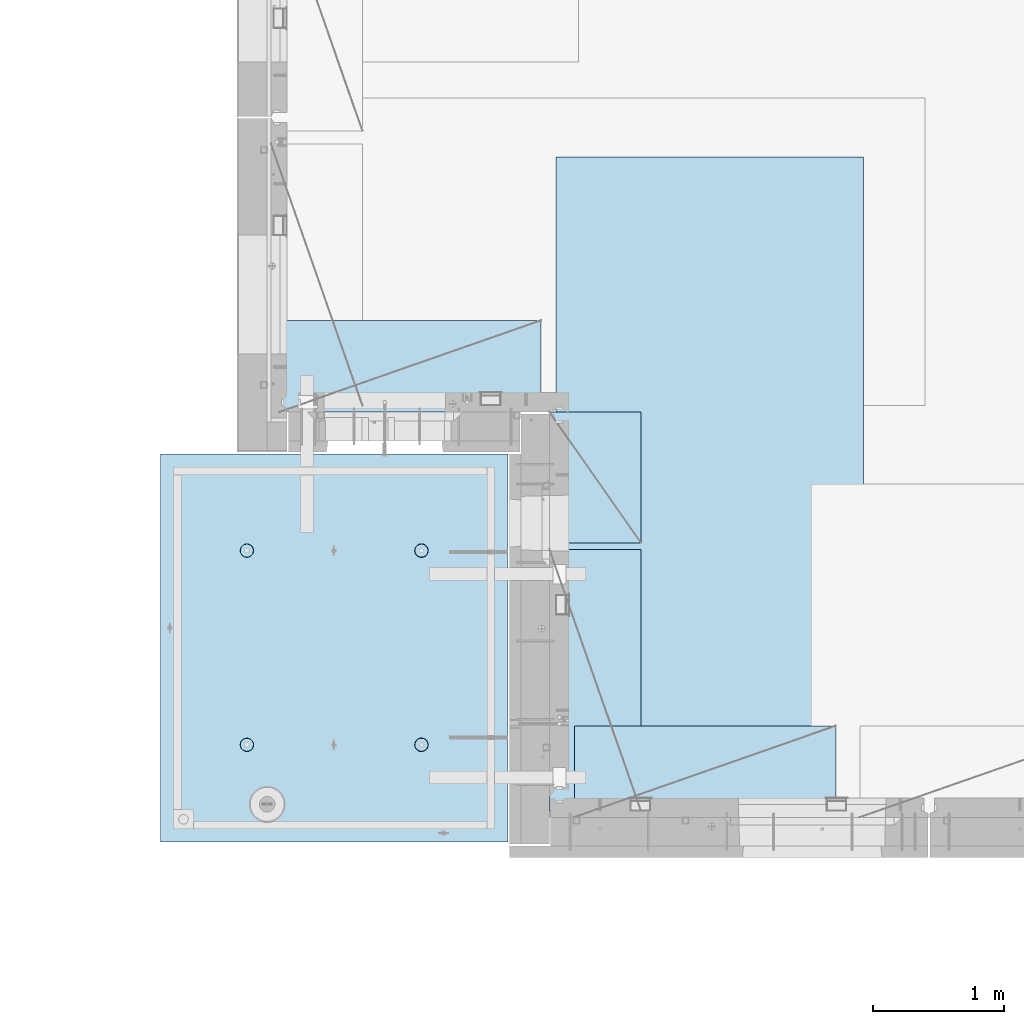
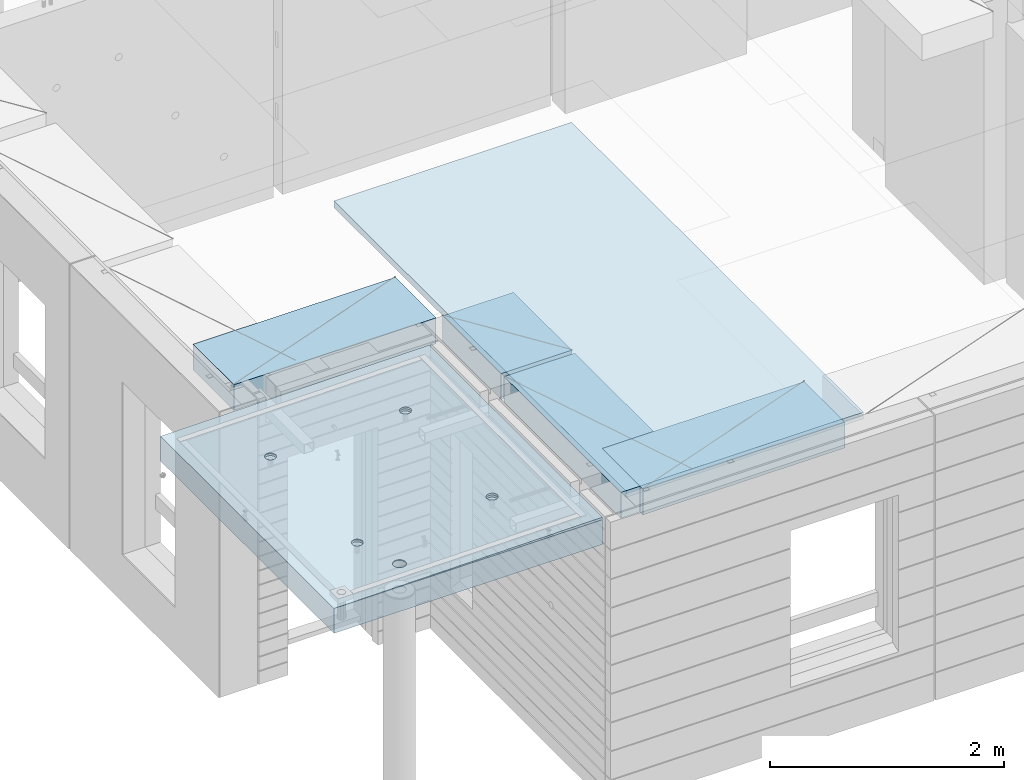
# One storey, part 192 of 334: 5 plates, 2 slabs, 6 elements without a shape of their own.
"""IFC2X3 building model written with IfcOpenShell, lengths in millimetres."""

from ifc_helpers import new_model, si_unit, frame, origin_with_axes, place, context, subcontext, project, spatial, faceted_brep, material, type_object, element, aggregate, save


model = new_model("IFC2X3")

# Units and contexts
model_context = context("Model", 3, precision=1e-05, world=origin_with_axes())
body_context = subcontext(model_context, "Body", "Model", "MODEL_VIEW")
ifc_project = project(units=[si_unit("LENGTHUNIT", "METRE", prefix="MILLI"), si_unit("AREAUNIT", "SQUARE_METRE"), si_unit("VOLUMEUNIT", "CUBIC_METRE"), si_unit("MASSUNIT", "GRAM", prefix="KILO"), si_unit("TIMEUNIT", "SECOND"), si_unit("PLANEANGLEUNIT", "RADIAN"), si_unit("SOLIDANGLEUNIT", "STERADIAN"), si_unit("THERMODYNAMICTEMPERATUREUNIT", "DEGREE_CELSIUS"), si_unit("LUMINOUSINTENSITYUNIT", "LUMEN")], contexts=[model_context])

# Site, building, storey
site_placement = place(None, origin_with_axes())
site = spatial("IfcSite", under=ifc_project, at=site_placement, CompositionType="ELEMENT")
building_placement = place(site_placement, origin_with_axes())
building = spatial("IfcBuilding", under=site, at=building_placement, CompositionType="ELEMENT")
storey_placement = place(building_placement, origin_with_axes())
storey = spatial("IfcBuildingStorey", under=building, at=storey_placement, Name="3", CompositionType="ELEMENT", Elevation=0.0)

# Assembly, slabs
assembly_1_placement = place(storey_placement, origin_with_axes())
assembly_1 = element("IfcElementAssembly", 1, at=assembly_1_placement, inside=storey, AssemblyPlace="NOTDEFINED", PredefinedType="REINFORCEMENT_UNIT")
ifc_material_1 = material(Name="CONCRETE/C35/45")
slab_type_1 = type_object("IfcSlabType", PredefinedType="NOTDEFINED")
slab_1_placement = place(assembly_1_placement, frame((9690.00344264774, 7659.99985681325, 90717.5), z_axis=(-1.0, 3.00000001838171e-08, 0.0), x_axis=(0.0, 1.0, 0.0)))
slab_1 = element("IfcSlab", 2, at=slab_1_placement, type_object=slab_type_1, material=ifc_material_1, PredefinedType="FLOOR", context=body_context, shape_type="Brep", body=[
    faceted_brep([(2970.0, 12.5, 2076.56396484375), (2970.0, 12.5, 2655.10375976563), (2970.0, 7.05330645262438, 2076.56396484375), (2970.0, 12.5, 0.0), (2969.99999999997, -12.5000027287315, -0.000215120240682154), (7.41420080885291e-08, 12.4999999999927, 0.0), (-7.41420080885291e-08, -12.5, -3.63797880709171e-12), (0.0, 12.5, 2655.00366210938), (2246.17288192116, -6.7539579669974, 610.235903379627), (2245.81872714612, 12.5, 611.325879700402), (2230.00000005311, 12.5, 608.820439463128), (2230.00000005311, -6.77809034052189, 607.672934085716), (2260.76019932669, -6.68392947182292, 617.673133503364), (2260.0890070157, 12.5, 618.596950465364), (2272.332530811, -6.57487936261168, 629.254531739907), (2271.41396524135, 12.5, 629.921908691014), (2279.75709784774, -6.43750647555862, 643.843854552742), (2278.68503600632, 12.5, 644.192188560603), (2282.30864751904, -6.2852774275234, 660.010915653605), (2281.19047624359, 12.5, 660.010915653605), (2279.73986529519, -6.13310092446045, 676.172377558725), (2278.68503600632, 12.5, 675.829642746608), (2272.30464795307, -5.995865551522, 690.747041485218), (2271.41396524135, 12.5, 690.099922616197), (2260.73231646608, -5.88698525390646, 702.310320338618), (2260.0890070157, 12.5, 701.424880841847), (2246.15564936427, -5.81709377811057, 709.732891570933), (2245.81872714612, 12.5, 708.695951606809), (2230.00000005311, -5.7930130083696, 712.290261666009), (2230.00000005311, 12.5, 711.201391844083), (2213.8443507625, -5.8170926610037, 709.732891507694), (2214.18127296011, 12.5, 708.695951606811), (2199.2676837145, -5.88698312871566, 702.310320236276), (2199.91099309052, 12.5, 701.424880841847), (2187.69535229405, -5.99586262571393, 690.747041382852), (2188.58603486487, 12.5, 690.099922616197), (2180.26013500581, -6.13309748387837, 676.172377495441), (2181.31496409991, 12.5, 675.829642746608), (2177.6913528026, -6.28527380865125, 660.010915653605), (2178.80952386264, 12.5, 660.010915653605), (2180.24290245339, -6.43750303260458, 643.843854616072), (2181.31496409991, 12.5, 644.192188560603), (2187.66746943631, -6.57487643294735, 629.254531842409), (2188.58603486487, 12.5, 629.921908691014), (2199.23980085403, -6.68392734277586, 617.673133605889), (2199.91099309052, 12.5, 618.596950465364), (2213.82711820565, -6.75395684751857, 610.235903443003), (2214.18127296011, 12.5, 611.325879700402), (761.172882674973, -6.75400078258826, 610.225900828256), (760.818727112381, 12.5, 611.315879572843), (745.000000019378, 12.5, 608.81043933557), (745.000000019378, -6.77813315729145, 607.662931409541), (775.760200790834, -6.68397228400863, 617.663131314152), (775.089006981969, 12.5, 618.586950337805), (787.33253283866, -6.57492216948594, 629.244530114656), (786.413965207619, 12.5, 629.911908563456), (794.757100236948, -6.437549275739, 643.833853637923), (793.685035972581, 12.5, 644.182188433044), (797.308650032492, -6.28532022031141, 660.000915526047), (796.190476209855, 12.5, 660.000915526047), (794.739867683551, -6.13314370981243, 676.162378218156), (793.685035972581, 12.5, 675.81964261905), (787.304649979378, -5.9959083302092, 690.737042854367), (786.413965207619, 12.5, 690.089922488638), (775.732317928869, -5.88702802728221, 702.300322270843), (775.089006981969, 12.5, 701.414880714288), (761.155650117242, -5.81713654809573, 709.722893864604), (760.818727112381, 12.5, 708.68595147925), (745.000000019378, -5.79305577717605, 712.280264084213), (745.000000019378, 12.5, 711.191391716524), (728.844349942063, -5.8171354309743, 709.722893801363), (729.181272926375, 12.5, 708.68595147925), (714.267682184241, -5.88702590207686, 702.300322168503), (714.910993056787, 12.5, 701.414880714288), (702.695350200273, -5.99590540440113, 690.737042752), (703.586034831136, 12.5, 690.089922488638), (695.260132549976, -6.1331402692449, 676.16237815487), (696.314964066174, 12.5, 675.81964261905), (692.691350221674, -6.28531660142471, 660.000915526047), (693.809523828902, 12.5, 660.000915526047), (695.242899996714, -6.43754583279951, 643.833853701251), (696.314964066174, 12.5, 644.182188433044), (702.667467341174, -6.57491923982161, 629.244530217156), (703.586034831136, 12.5, 629.911908563456), (714.239799322411, -6.68397015496157, 617.663131416677), (714.910993056787, 12.5, 618.586950337805), (728.827117384375, -6.75399966310943, 610.225900891632), (729.181272926375, 12.5, 611.315879572843), (760.941541335169, 5.82308796475991, 1945.93972725137), (760.818727091786, 12.5, 1946.31771062636), (744.999999998783, 12.5, 1943.81227038909), (744.999999998783, 5.79930078610778, 1943.4134192454), (775.320198478928, 5.89211475661432, 1953.2705735664), (775.089006961374, 12.5, 1953.58878139132), (786.72699673669, 5.99960498859582, 1964.68630888353), (786.413965187025, 12.5, 1964.91373961697), (794.045361100365, 6.13501286304381, 1979.06694274881), (793.685035951987, 12.5, 1979.18401948656), (796.560412832556, 6.28506439260673, 1995.00274657956), (796.190476189258, 12.5, 1995.00274657956), (794.028375046106, 6.43506412883289, 2010.93303130673), (793.685035951987, 12.5, 2010.82147367257), (786.699512721421, 6.57033645619231, 2025.29921596966), (786.413965187025, 12.5, 2025.09175354215), (775.292714461017, 6.67765930559835, 2036.69709108738), (775.089006961374, 12.5, 2036.41671176781), (760.924555276639, 6.74655103802797, 2044.01348819506), (760.818727091786, 12.5, 2043.68778253277), (744.999999998783, 6.7702873510425, 2046.53427709438), (744.999999998783, 12.5, 2046.19322277004), (729.075444741182, 6.7465521391714, 2044.01348813272), (729.18127290578, 12.5, 2043.68778253277), (714.70728560984, 6.67766140039021, 2036.6970909865), (714.910993036192, 12.5, 2036.41671176781), (703.300487415023, 6.57033934014908, 2025.29921586876), (703.586034810542, 12.5, 2025.09175354216), (695.971625143447, 6.43506752018584, 2010.93303124435), (696.314964045579, 12.5, 2010.82147367257), (693.439587377337, 6.28506795971771, 1995.00274657956), (693.809523808306, 12.5, 1995.00274657956), (695.954639089321, 6.13501625673962, 1979.06694281123), (696.314964045579, 12.5, 1979.18401948656), (703.273003399938, 5.99960787635064, 1964.68630898457), (703.586034810542, 12.5, 1964.91373961697), (714.679801592063, 5.89211685521877, 1953.27057366746), (714.910993036192, 12.5, 1953.58878139132), (729.058458682694, 5.82308906823164, 1945.93972731384), (729.18127290578, 12.5, 1946.31771062636), (2178.80952377932, 12.5, 1995.00274667064), (2178.43958429075, 6.28501659208268, 1995.00274667064), (2180.95463615188, 6.13496488021337, 1979.06694195729), (2181.31496401659, 12.5, 1979.18401957764), (2181.31496401659, 12.5, 2010.82147376364), (2180.97162220701, 6.43501616145659, 2010.93303228012), (2188.58603478155, 12.5, 2025.09175363323), (2188.3004849132, 6.57028798943793, 2025.29921775646), (2199.9109930072, 12.5, 2036.41671185888), (2199.70728378446, 6.6776100560528, 2036.6970935501), (2214.18127287679, 12.5, 2043.68778262385), (2214.07544376785, 6.74650079890853, 2044.0134911302), (2229.9999999698, 12.5, 2046.19322286112), (2229.9999999698, 6.77023601217661, 2046.53428024135), (2245.8187270628, 12.5, 2043.68778262385), (2245.924556192, 6.7464996977651, 2044.01349119253), (2260.08900693239, 12.5, 2036.41671185888), (2260.29271622843, 6.67760796126095, 2036.69709365098), (2271.41396515804, 12.5, 2025.09175363323), (2271.69951516527, 6.57028510548116, 2025.29921785736), (2278.685035923, 12.5, 2010.82147376364), (2279.02837792456, 6.43501277010364, 2010.9330323425), (2281.19047616027, 12.5, 1995.00274667064), (2281.56041586117, 6.2850130249717, 1995.00274667064), (2278.685035923, 12.5, 1979.18401957764), (2279.04536397983, 6.13496148651757, 1979.06694189487), (2271.41396515804, 12.5, 1964.91373970805), (2271.72699918216, 5.99955360403692, 1964.68630717681), (2260.08900693239, 12.5, 1953.5887814824), (2260.32020024797, 5.89206336568168, 1953.2705711827), (2245.8187270628, 12.5, 1946.31771071744), (2245.94154225154, 5.82303656973818, 1945.93972443295), (254.731823253564, 4.36849820162752, 1791.45731182264), (241.457918728614, 4.49348581883532, 1804.73121634759), (232.935547413403, 4.65097912067722, 1821.45731182264), (229.998938391112, 4.82556156541978, 1839.99833148514), (232.935547413403, 5.00014380698849, 1858.53935114764), (241.457918728614, 5.15763651921588, 1875.26544662269), (254.731823253564, 5.28262321809598, 1888.53935114764), (271.457918728614, 5.36286933471274, 1897.06172246285), (289.998938391112, 5.3905198200664, 1899.99833148514), (308.539958053609, 5.36286805199052, 1897.06172246285), (325.26605352866, 5.28262077822001, 1888.53935114764), (338.539958053609, 5.15763316099765, 1875.26544662269), (347.06232936882, 5.0001398591703, 1858.53935114764), (349.998938391112, 4.82555741442775, 1839.99833148514), (347.06232936882, 4.65097517284448, 1821.45731182264), (338.539958053609, 4.49348246061709, 1804.73121634759), (325.26605352866, 4.36849576173699, 1791.45731182264), (308.539958053609, 4.28824964510568, 1782.93494050743), (289.998938391112, 4.26059915976657, 1779.99833148514), (271.457918728614, 4.28825092784246, 1782.93494050743), (2199.67979976505, 5.89206546428613, 1953.27057128376), (2188.27300089649, 5.99955649179174, 1964.68630727784), (2229.9999999698, 5.79924938967451, 1943.41341627717), (2214.05845770835, 5.82303767320991, 1945.93972449542), (2188.58603478155, 12.5, 1964.91373970805), (2199.9109930072, 12.5, 1953.5887814824), (2214.18127287679, 12.5, 1946.31771071744), (2229.9999999698, 12.5, 1943.81227048017), (325.26605352866, 12.5, 1791.45731182264), (338.539958053609, 12.5, 1804.73121634759), (347.06232936882, 12.5, 1821.45731182264), (349.998938391112, 12.5, 1839.99833148514), (347.06232936882, 12.5, 1858.53935114764), (338.539958053609, 12.5, 1875.26544662269), (325.26605352866, 12.5, 1888.53935114764), (308.539958053609, 12.5, 1897.06172246285), (289.998938391112, 12.5, 1899.99833148514), (271.457918728614, 12.5, 1897.06172246285), (254.731823253564, 12.5, 1888.53935114764), (241.457918728614, 12.5, 1875.26544662269), (232.935547413403, 12.5, 1858.53935114764), (229.998938391112, 12.5, 1839.99833148514), (232.935547413403, 12.5, 1821.45731182264), (241.457918728614, 12.5, 1804.73121634759), (254.731823253564, 12.5, 1791.45731182264), (271.457918728614, 12.5, 1782.93494050743), (289.998938391112, 12.5, 1779.99833148514), (308.539958053609, 12.5, 1782.93494050743)], [[[0, 1, 2]], [[3, 0, 2, 4]], [[5, 3, 4, 6]], [[5, 6, 7]], [[8, 9, 10, 11]], [[12, 13, 9, 8]], [[14, 15, 13, 12]], [[16, 17, 15, 14]], [[18, 19, 17, 16]], [[20, 21, 19, 18]], [[21, 20, 22, 23]], [[23, 22, 24, 25]], [[25, 24, 26, 27]], [[27, 26, 28, 29]], [[29, 28, 30, 31]], [[31, 30, 32, 33]], [[33, 32, 34, 35]], [[35, 34, 36, 37]], [[37, 36, 38, 39]], [[40, 41, 39, 38]], [[42, 43, 41, 40]], [[44, 45, 43, 42]], [[46, 47, 45, 44]], [[11, 10, 47, 46]], [[48, 49, 50, 51]], [[52, 53, 49, 48]], [[54, 55, 53, 52]], [[56, 57, 55, 54]], [[58, 59, 57, 56]], [[60, 61, 59, 58]], [[61, 60, 62, 63]], [[63, 62, 64, 65]], [[65, 64, 66, 67]], [[67, 66, 68, 69]], [[69, 68, 70, 71]], [[71, 70, 72, 73]], [[73, 72, 74, 75]], [[75, 74, 76, 77]], [[77, 76, 78, 79]], [[80, 81, 79, 78]], [[82, 83, 81, 80]], [[84, 85, 83, 82]], [[86, 87, 85, 84]], [[51, 50, 87, 86]], [[88, 89, 90, 91]], [[92, 93, 89, 88]], [[94, 95, 93, 92]], [[96, 97, 95, 94]], [[98, 99, 97, 96]], [[100, 101, 99, 98]], [[102, 103, 101, 100]], [[104, 105, 103, 102]], [[105, 104, 106, 107]], [[107, 106, 108, 109]], [[109, 108, 110, 111]], [[111, 110, 112, 113]], [[113, 112, 114, 115]], [[115, 114, 116, 117]], [[117, 116, 118, 119]], [[119, 118, 120, 121]], [[121, 120, 122, 123]], [[124, 125, 123, 122]], [[126, 127, 125, 124]], [[91, 90, 127, 126]], [[128, 129, 130, 131]], [[132, 133, 129, 128]], [[134, 135, 133, 132]], [[136, 137, 135, 134]], [[138, 139, 137, 136]], [[140, 141, 139, 138]], [[142, 143, 141, 140]], [[144, 145, 143, 142]], [[145, 144, 146, 147]], [[147, 146, 148, 149]], [[149, 148, 150, 151]], [[151, 150, 152, 153]], [[153, 152, 154, 155]], [[155, 154, 156, 157]], [[157, 156, 158, 159]], [[4, 2, 1, 7, 6], [160, 161, 162, 163, 164, 165, 166, 167, 168, 169, 170, 171, 172, 173, 174, 175, 176, 177, 178, 179], [180, 181, 130, 129, 133, 135, 137, 139, 141, 143, 145, 147, 149, 151, 153, 155, 157, 159, 182, 183], [124, 122, 120, 118, 116, 114, 112, 110, 108, 106, 104, 102, 100, 98, 96, 94, 92, 88, 91, 126], [84, 82, 80, 78, 76, 74, 72, 70, 68, 66, 64, 62, 60, 58, 56, 54, 52, 48, 51, 86], [44, 42, 40, 38, 36, 34, 32, 30, 28, 26, 24, 22, 20, 18, 16, 14, 12, 8, 11, 46]], [[131, 130, 181, 184]], [[180, 185, 184, 181]], [[183, 186, 185, 180]], [[182, 187, 186, 183]], [[159, 158, 187, 182]], [[0, 3, 5, 7, 1], [188, 189, 190, 191, 192, 193, 194, 195, 196, 197, 198, 199, 200, 201, 202, 203, 204, 205, 206, 207], [156, 154, 152, 150, 148, 146, 144, 142, 140, 138, 136, 134, 132, 128, 131, 184, 185, 186, 187, 158], [93, 95, 97, 99, 101, 103, 105, 107, 109, 111, 113, 115, 117, 119, 121, 123, 125, 127, 90, 89], [53, 55, 57, 59, 61, 63, 65, 67, 69, 71, 73, 75, 77, 79, 81, 83, 85, 87, 50, 49], [13, 15, 17, 19, 21, 23, 25, 27, 29, 31, 33, 35, 37, 39, 41, 43, 45, 47, 10, 9]], [[178, 206, 205, 179]], [[177, 207, 206, 178]], [[176, 188, 207, 177]], [[175, 189, 188, 176]], [[174, 190, 189, 175]], [[173, 191, 190, 174]], [[172, 192, 191, 173]], [[171, 193, 192, 172]], [[170, 194, 193, 171]], [[169, 195, 194, 170]], [[168, 196, 195, 169]], [[167, 197, 196, 168]], [[166, 198, 197, 167]], [[165, 199, 198, 166]], [[164, 200, 199, 165]], [[163, 201, 200, 164]], [[162, 202, 201, 163]], [[161, 203, 202, 162]], [[160, 204, 203, 161]], [[179, 205, 204, 160]]]),
])
slab_type_2 = type_object("IfcSlabType", PredefinedType="NOTDEFINED")
slab_2_placement = place(assembly_1_placement, frame((9690.00344264774, 7659.99985681325, 90575.0), z_axis=(-0.999999999997437, -2.26400000064461e-06, 0.0), x_axis=(-2.2639999995273e-06, 0.999999999997437, 0.0)))
slab_2 = element("IfcSlab", 3, at=slab_2_placement, type_object=slab_type_2, material=ifc_material_1, PredefinedType="FLOOR", context=body_context, shape_type="Brep", body=[
    faceted_brep([(2245.45536387143, -110.0, 1947.44471589559), (2259.39379322965, -110.0, 1954.54665968234), (2270.4554059745, -110.0, 1965.60822114567), (2277.55741437973, -110.0, 1979.54661757913), (2280.00462438004, -110.0, 1994.99746162528), (2277.55748600988, -110.0, 2010.44831701654), (2270.45554222312, -110.0, 2024.38674637476), (2259.39398075979, -110.0, 2035.44835911961), (2245.45558432633, -110.0, 2042.55036752485), (2230.00474028018, -110.0, 2044.99757752515), (2214.55388488892, -110.0, 2042.55043915498), (2200.6154555307, -110.0, 2035.44849536823), (2189.55384278585, -110.0, 2024.3869339049), (2182.45183438062, -110.0, 2010.44853747144), (2180.00462438031, -110.0, 1994.99769342529), (2182.45176275048, -110.0, 1979.54683803403), (2189.55370653723, -110.0, 1965.60840867581), (2200.61526800056, -110.0, 1954.54679593096), (2214.55366443402, -110.0, 1947.44478752572), (2230.00450848018, -110.0, 1944.99757752542), (2260.09353534512, -130.0, 1953.58354259084), (2245.82323862122, -130.0, 1946.3125049044), (2271.41851982199, -130.0, 1964.9084745652), (2278.68962366544, -130.0, 1979.17873758041), (2281.19510057052, -130.0, 1994.99745886576), (2278.68969700106, -130.0, 2010.81619176633), (2271.41865931462, -130.0, 2025.08648849022), (2260.09372734026, -130.0, 2036.4114729671), (2245.82346432505, -130.0, 2043.68257681055), (2230.0047430397, -130.0, 2046.18805371562), (2214.18601013913, -130.0, 2043.68265014617), (2199.91571341524, -130.0, 2036.41161245973), (2188.59072893836, -130.0, 2025.08668048537), (2181.31962509491, -130.0, 2010.81641747016), (2178.81414818984, -130.0, 1994.99769618481), (2181.31955175929, -130.0, 1979.17896328424), (2188.59058944573, -130.0, 1964.90866656035), (2199.91552142009, -130.0, 1953.58368208347), (2214.1857844353, -130.0, 1946.31257824002), (2230.00450572065, -130.0, 1943.80710133495), (760.455363904408, -110.0, 1947.44815803451), (774.393793262629, -110.0, 1954.55010182126), (785.455406007481, -110.0, 1965.61166328459), (792.557414412711, -110.0, 1979.55005971805), (795.004624413019, -110.0, 1995.00090376421), (792.557486042851, -110.0, 2010.45175915546), (785.455542256102, -110.0, 2024.39018851368), (774.393980792767, -110.0, 2035.45180125853), (760.455584359308, -110.0, 2042.55380966377), (745.004740313152, -110.0, 2045.00101966407), (729.553884921896, -110.0, 2042.55388129391), (715.615455563677, -110.0, 2035.45193750716), (704.553842818825, -110.0, 2024.39037604382), (697.451834413594, -110.0, 2010.45197961036), (695.004624413286, -110.0, 1995.00113556421), (697.451762783454, -110.0, 1979.55028017295), (704.553706570203, -110.0, 1965.61185081473), (715.615268033538, -110.0, 1954.55023806988), (729.553664466996, -110.0, 1947.44822966465), (745.004508513151, -110.0, 1945.00101966434), (760.823238654199, -130.0, 1946.31594704332), (745.004505753628, -130.0, 1943.81054347387), (775.093535378091, -130.0, 1953.58698472976), (786.418519854964, -130.0, 1964.91191670413), (793.689623698416, -130.0, 1979.18217971933), (796.195100603492, -130.0, 1995.00090100468), (793.689697034035, -130.0, 2010.81963390525), (786.418659347601, -130.0, 2025.08993062915), (775.093727373234, -130.0, 2036.41491510602), (760.823464358025, -130.0, 2043.68601894947), (745.004743072675, -130.0, 2046.19149585455), (729.186010172105, -130.0, 2043.68609228509), (714.915713448214, -130.0, 2036.41505459866), (703.590728971341, -130.0, 2025.09012262429), (696.319625127888, -130.0, 2010.81985960908), (693.814148222813, -130.0, 1995.00113832373), (696.319551792269, -130.0, 1979.18240542316), (703.590589478705, -130.0, 1964.91210869927), (714.915521453071, -130.0, 1953.5871242224), (729.185784468278, -130.0, 1946.31602037894), (2970.0, -130.0, 1.11504050437361e-09), (0.0, -130.0, -3.63797880709171e-12), (0.0, 130.0, -1.81898940354586e-12), (2970.0, 130.0, 1.11504050437361e-09), (2970.0048828125, -130.0, 2076.55712890625), (2970.0048828125, 130.0, 2076.55712890625), (2970.00610351563, -130.0, 2655.0966796875), (2970.00610351563, 130.0, 2655.0966796875), (0.00277573079893045, -130.0, 2655.00366210937), (0.00277573079893045, 130.0, 2655.00366210937), (325.270206125839, 130.0, 1791.45655785112), (338.544141419662, 130.0, 1804.73043160713), (347.066551505941, 130.0, 1821.45650732727), (350.003203506308, 130.0, 1839.99752018266), (347.066637462108, 130.0, 1858.53854665217), (338.544304918008, 130.0, 1875.26466188203), (325.270431162006, 130.0, 1888.53859717586), (308.544355441856, 130.0, 1897.06100726213), (290.003342586469, 130.0, 1899.9976592625), (271.462316116962, 130.0, 1897.0610932183), (254.7362008871, 130.0, 1888.5387606742), (241.462265593274, 130.0, 1875.2648869182), (232.939855506997, 130.0, 1858.53881119805), (230.00320350663, 130.0, 1839.99779834266), (232.93976955083, 130.0, 1821.45677187316), (241.462102094929, 130.0, 1804.73065664329), (254.735975850932, 130.0, 1791.45672134947), (271.462051571081, 130.0, 1782.93431126319), (290.003064426469, 130.0, 1779.99765926282), (308.544090895975, 130.0, 1782.93422530702), (308.544090895975, -130.0, 1782.93422530702), (290.003064426469, -130.0, 1779.99765926282), (325.270206125839, -130.0, 1791.45655785112), (338.544141419662, -130.0, 1804.73043160713), (347.066551505941, -130.0, 1821.45650732727), (350.003203506308, -130.0, 1839.99752018266), (347.066637462108, -130.0, 1858.53854665217), (338.544304918008, -130.0, 1875.26466188203), (325.270431162006, -130.0, 1888.53859717586), (308.544355441856, -130.0, 1897.06100726213), (290.003342586469, -130.0, 1899.9976592625), (271.462316116962, -130.0, 1897.0610932183), (254.7362008871, -130.0, 1888.5387606742), (241.462265593274, -130.0, 1875.2648869182), (232.939855506997, -130.0, 1858.53881119805), (230.00320350663, -130.0, 1839.99779834266), (232.93976955083, -130.0, 1821.45677187316), (241.462102094929, -130.0, 1804.73065664329), (254.735975850932, -130.0, 1791.45672134947), (271.462051571081, -130.0, 1782.93431126319), (760.452269390758, -110.0, 612.446326984578), (774.390698748979, -110.0, 619.548270771327), (785.452311493831, -110.0, 630.609832234661), (792.554319899062, -110.0, 644.54822866812), (795.001529899369, -110.0, 659.999072714278), (792.554391529202, -110.0, 675.449928105532), (785.452447742453, -110.0, 689.388357463751), (774.390886279118, -110.0, 700.449970208605), (760.452489845658, -110.0, 707.551978613836), (745.001645799503, -110.0, 709.999188614142), (729.550790408246, -110.0, 707.552050243974), (715.612361050027, -110.0, 700.450106457225), (704.550748305175, -110.0, 689.388544993892), (697.448739899944, -110.0, 675.450148560432), (695.001529899637, -110.0, 659.999304514276), (697.448668269804, -110.0, 644.54844912302), (704.550612056553, -110.0, 630.610019764801), (715.612173519889, -110.0, 619.548407019947), (729.550569953346, -110.0, 612.446398614717), (745.001413999502, -110.0, 609.999188614411), (760.820144140549, -130.0, 611.314115993395), (745.001411239979, -130.0, 608.808712423936), (775.090440864442, -130.0, 618.585153679829), (786.415425341314, -130.0, 629.910085654195), (793.686529184766, -130.0, 644.180348669403), (796.192006089843, -130.0, 659.999069954752), (793.686602520385, -130.0, 675.817802855323), (786.415564833951, -130.0, 690.088099579216), (775.090632859585, -130.0, 701.41308405609), (760.820369844376, -130.0, 708.68418789954), (745.001648559026, -130.0, 711.189664804615), (729.182915658455, -130.0, 708.684261235159), (714.912618934564, -130.0, 701.413223548725), (703.587634457692, -130.0, 690.088291574357), (696.316530614238, -130.0, 675.81802855915), (693.811053709163, -130.0, 659.999307273802), (696.316457278619, -130.0, 644.180574373229), (703.587494965055, -130.0, 629.910277649336), (714.912426939421, -130.0, 618.585293172464), (729.182689954629, -130.0, 611.314189329014), (2245.45226944368, -110.0, 612.452884882137), (2259.3906988019, -110.0, 619.554828668886), (2270.45231154675, -110.0, 630.61639013222), (2277.55431995199, -110.0, 644.554786565679), (2280.00152995229, -110.0, 660.005630611837), (2277.55439158212, -110.0, 675.456486003091), (2270.45244779537, -110.0, 689.39491536131), (2259.39088633204, -110.0, 700.456528106164), (2245.45248989858, -110.0, 707.558536511395), (2230.00164585242, -110.0, 710.005746511701), (2214.55079046117, -110.0, 707.558608141533), (2200.61236110295, -110.0, 700.456664354784), (2189.5507483581, -110.0, 689.395102891451), (2182.44873995286, -110.0, 675.456706457991), (2180.00152995256, -110.0, 660.005862411836), (2182.44866832273, -110.0, 644.555007020579), (2189.55061210948, -110.0, 630.61657766236), (2200.61217357281, -110.0, 619.554964917506), (2214.55057000627, -110.0, 612.452956512276), (2230.00141405243, -110.0, 610.00574651197), (2245.82014419347, -130.0, 611.320673890954), (2230.0014112929, -130.0, 608.815270321495), (2260.09044091736, -130.0, 618.591711577388), (2271.41542539424, -130.0, 629.916643551753), (2278.68652923769, -130.0, 644.186906566962), (2281.19200614276, -130.0, 660.005627852312), (2278.68660257331, -130.0, 675.824360752882), (2271.41556488687, -130.0, 690.094657476773), (2260.09063291251, -130.0, 701.419641953647), (2245.8203698973, -130.0, 708.690745797099), (2230.00164861195, -130.0, 711.196222702174), (2214.18291571138, -130.0, 708.690819132718), (2199.91261898749, -130.0, 701.419781446282), (2188.58763451061, -130.0, 690.094849471916), (2181.31653066716, -130.0, 675.824586456709), (2178.81105376209, -130.0, 660.005865171361), (2181.31645733154, -130.0, 644.187132270788), (2188.58749501798, -130.0, 629.916835546896), (2199.91242699234, -130.0, 618.591851070023), (2214.18269000755, -130.0, 611.320747226573)], [[[0, 1, 2, 3, 4, 5, 6, 7, 8, 9, 10, 11, 12, 13, 14, 15, 16, 17, 18, 19]], [[20, 1, 0, 21]], [[22, 2, 1, 20]], [[23, 3, 2, 22]], [[24, 4, 3, 23]], [[25, 5, 4, 24]], [[26, 6, 5, 25]], [[27, 7, 6, 26]], [[28, 8, 7, 27]], [[29, 9, 8, 28]], [[30, 10, 9, 29]], [[31, 11, 10, 30]], [[32, 12, 11, 31]], [[33, 13, 12, 32]], [[34, 14, 13, 33]], [[35, 15, 14, 34]], [[36, 16, 15, 35]], [[37, 17, 16, 36]], [[38, 18, 17, 37]], [[39, 19, 18, 38]], [[21, 0, 19, 39]], [[40, 41, 42, 43, 44, 45, 46, 47, 48, 49, 50, 51, 52, 53, 54, 55, 56, 57, 58, 59]], [[60, 40, 59, 61]], [[62, 41, 40, 60]], [[63, 42, 41, 62]], [[64, 43, 42, 63]], [[65, 44, 43, 64]], [[66, 45, 44, 65]], [[67, 46, 45, 66]], [[68, 47, 46, 67]], [[69, 48, 47, 68]], [[70, 49, 48, 69]], [[71, 50, 49, 70]], [[72, 51, 50, 71]], [[73, 52, 51, 72]], [[74, 53, 52, 73]], [[75, 54, 53, 74]], [[76, 55, 54, 75]], [[77, 56, 55, 76]], [[78, 57, 56, 77]], [[79, 58, 57, 78]], [[61, 59, 58, 79]], [[80, 81, 82, 83]], [[84, 80, 83, 85]], [[86, 84, 85, 87]], [[88, 86, 87, 89]], [[81, 88, 89, 82]], [[87, 85, 83, 82, 89], [90, 91, 92, 93, 94, 95, 96, 97, 98, 99, 100, 101, 102, 103, 104, 105, 106, 107, 108, 109]], [[110, 109, 108, 111]], [[112, 90, 109, 110]], [[113, 91, 90, 112]], [[114, 92, 91, 113]], [[115, 93, 92, 114]], [[116, 94, 93, 115]], [[117, 95, 94, 116]], [[118, 96, 95, 117]], [[119, 97, 96, 118]], [[120, 98, 97, 119]], [[121, 99, 98, 120]], [[122, 100, 99, 121]], [[123, 101, 100, 122]], [[124, 102, 101, 123]], [[125, 103, 102, 124]], [[126, 104, 103, 125]], [[127, 105, 104, 126]], [[128, 106, 105, 127]], [[129, 107, 106, 128]], [[111, 108, 107, 129]], [[130, 131, 132, 133, 134, 135, 136, 137, 138, 139, 140, 141, 142, 143, 144, 145, 146, 147, 148, 149]], [[150, 130, 149, 151]], [[152, 131, 130, 150]], [[153, 132, 131, 152]], [[154, 133, 132, 153]], [[155, 134, 133, 154]], [[156, 135, 134, 155]], [[157, 136, 135, 156]], [[158, 137, 136, 157]], [[159, 138, 137, 158]], [[160, 139, 138, 159]], [[161, 140, 139, 160]], [[162, 141, 140, 161]], [[163, 142, 141, 162]], [[164, 143, 142, 163]], [[165, 144, 143, 164]], [[166, 145, 144, 165]], [[167, 146, 145, 166]], [[168, 147, 146, 167]], [[169, 148, 147, 168]], [[151, 149, 148, 169]], [[170, 171, 172, 173, 174, 175, 176, 177, 178, 179, 180, 181, 182, 183, 184, 185, 186, 187, 188, 189]], [[190, 170, 189, 191]], [[192, 171, 170, 190]], [[193, 172, 171, 192]], [[194, 173, 172, 193]], [[195, 174, 173, 194]], [[196, 175, 174, 195]], [[197, 176, 175, 196]], [[198, 177, 176, 197]], [[199, 178, 177, 198]], [[200, 179, 178, 199]], [[201, 180, 179, 200]], [[202, 181, 180, 201]], [[203, 182, 181, 202]], [[204, 183, 182, 203]], [[205, 184, 183, 204]], [[206, 185, 184, 205]], [[207, 186, 185, 206]], [[208, 187, 186, 207]], [[209, 188, 187, 208]], [[191, 189, 188, 209]], [[80, 84, 86, 88, 81], [37, 36, 35, 34, 33, 32, 31, 30, 29, 28, 27, 26, 25, 24, 23, 22, 20, 21, 39, 38], [208, 207, 206, 205, 204, 203, 202, 201, 200, 199, 198, 197, 196, 195, 194, 193, 192, 190, 191, 209], [168, 167, 166, 165, 164, 163, 162, 161, 160, 159, 158, 157, 156, 155, 154, 153, 152, 150, 151, 169], [128, 127, 126, 125, 124, 123, 122, 121, 120, 119, 118, 117, 116, 115, 114, 113, 112, 110, 111, 129], [78, 77, 76, 75, 74, 73, 72, 71, 70, 69, 68, 67, 66, 65, 64, 63, 62, 60, 61, 79]]]),
])
aggregate(assembly_1, [slab_1, slab_2])

# Assembly, plate
assembly_2_placement = place(storey_placement, origin_with_axes())
assembly_2 = element("IfcElementAssembly", 4, at=assembly_2_placement, inside=storey, Name="Steel Assembly", AssemblyPlace="NOTDEFINED", PredefinedType="NOTDEFINED")
ifc_material_2 = material()
plate_type_1 = type_object("IfcPlateType", PredefinedType="NOTDEFINED")
plate_1_placement = place(assembly_2_placement, frame((10060.0, 7900.0, 90695.1), z_axis=(0.0, 1.0, 0.0), x_axis=(1.0, 0.0, 0.0)))
plate_1 = element("IfcPlate", 5, at=plate_1_placement, type_object=plate_type_1, material=ifc_material_2, context=body_context, shape_type="Brep", body=[
    faceted_brep([(0.0, -35.0, 0.0), (0.0, -35.0, 5000.0), (0.0, 35.0, 5000.0), (0.0, 35.0, 0.0), (2349.99951171875, -35.0, 5000.0), (2349.99951171875, 35.0, 5000.0), (2350.0, -35.0, 0.0), (2350.0, 35.0, 0.0)], [[[0, 1, 2, 3]], [[1, 4, 5, 2]], [[4, 6, 7, 5]], [[6, 0, 3, 7]], [[5, 7, 3, 2]], [[6, 4, 1, 0]]]),
])
aggregate(assembly_2, [plate_1])

assembly_3_placement = place(storey_placement, origin_with_axes())
assembly_3 = element("IfcElementAssembly", 6, at=assembly_3_placement, inside=storey, Name="Steel Assembly", AssemblyPlace="NOTDEFINED", PredefinedType="NOTDEFINED")
plate_type_2 = type_object("IfcPlateType", PredefinedType="NOTDEFINED")
plate_2_placement = place(assembly_3_placement, frame((7945.00085423865, 10950.0001036336, 90595.3), z_axis=(0.0, 1.0, 0.0), x_axis=(1.0, 0.0, 0.0)))
plate_2 = element("IfcPlate", 7, at=plate_2_placement, type_object=plate_type_2, material=ifc_material_2, Name="RE1", context=body_context, shape_type="Brep", body=[
    faceted_brep([(1.81898940354586e-12, -135.0, 1.81898940354586e-12), (0.0, -135.0, 699.999999999996), (0.0, 135.0, 699.999999999996), (1.81898940354586e-12, 135.0, 1.81898940354586e-12), (1999.99951171875, -135.0, 699.999999999993), (1999.99951171875, 135.0, 699.999999999993), (2000.0, -135.0, -3.63797880709171e-12), (2000.0, 135.0, -3.63797880709171e-12)], [[[0, 1, 2, 3]], [[1, 4, 5, 2]], [[4, 6, 7, 5]], [[6, 0, 3, 7]], [[5, 7, 3, 2]], [[6, 4, 1, 0]]]),
])
aggregate(assembly_3, [plate_2])

assembly_4_placement = place(storey_placement, origin_with_axes())
assembly_4 = element("IfcElementAssembly", 8, at=assembly_4_placement, inside=storey, Name="Steel Assembly", AssemblyPlace="NOTDEFINED", PredefinedType="NOTDEFINED")
plate_3_placement = place(assembly_4_placement, frame((10009.9998779297, 9900.0, 90595.3), z_axis=(1.0, 0.0, 0.0), x_axis=(0.0, -1.0, 0.0)))
plate_3 = element("IfcPlate", 9, at=plate_3_placement, type_object=plate_type_2, material=ifc_material_2, Name="RE1", context=body_context, shape_type="Brep", body=[
    faceted_brep([(1.81898940354586e-12, -135.0, 1.81898940354586e-12), (0.0, -135.0, 699.999999999996), (0.0, 135.0, 699.999999999996), (1.81898940354586e-12, 135.0, 1.81898940354586e-12), (1999.99951171875, -135.0, 699.999999999993), (1999.99951171875, 135.0, 699.999999999993), (2000.0, -135.0, -3.63797880709171e-12), (2000.0, 135.0, -3.63797880709171e-12)], [[[0, 1, 2, 3]], [[1, 4, 5, 2]], [[4, 6, 7, 5]], [[6, 0, 3, 7]], [[5, 7, 3, 2]], [[6, 4, 1, 0]]]),
])
aggregate(assembly_4, [plate_3])

assembly_5_placement = place(storey_placement, origin_with_axes())
assembly_5 = element("IfcElementAssembly", 10, at=assembly_5_placement, inside=storey, Name="Steel Assembly", AssemblyPlace="NOTDEFINED", PredefinedType="NOTDEFINED")
plate_4_placement = place(assembly_5_placement, frame((10009.9999999293, 10950.0, 90595.3), z_axis=(1.0, 0.0, 0.0), x_axis=(0.0, -1.0, 0.0)))
plate_4 = element("IfcPlate", 11, at=plate_4_placement, type_object=plate_type_2, material=ifc_material_2, Name="RE1_1/2", context=body_context, shape_type="Brep", body=[
    faceted_brep([(1.81898940354586e-12, -135.0, 1.81898940354586e-12), (0.0, -135.0, 699.999999999996), (0.0, 135.0, 699.999999999996), (1.81898940354586e-12, 135.0, 1.81898940354586e-12), (999.99951171875, -135.0, 700.0), (999.99951171875, 135.0, 700.0), (1000.0, -135.0, 0.0), (1000.0, 135.0, 0.0)], [[[0, 1, 2, 3]], [[1, 4, 5, 2]], [[4, 6, 7, 5]], [[6, 0, 3, 7]], [[5, 7, 3, 2]], [[6, 4, 1, 0]]]),
])
aggregate(assembly_5, [plate_4])

assembly_6_placement = place(storey_placement, origin_with_axes())
assembly_6 = element("IfcElementAssembly", 12, at=assembly_6_placement, inside=storey, Name="Steel Assembly", AssemblyPlace="NOTDEFINED", PredefinedType="NOTDEFINED")
plate_5_placement = place(assembly_6_placement, frame((10200.0008542386, 7850.00010363356, 90595.3), z_axis=(0.0, 1.0, 0.0), x_axis=(1.0, 0.0, 0.0)))
plate_5 = element("IfcPlate", 13, at=plate_5_placement, type_object=plate_type_2, material=ifc_material_2, Name="RE1", context=body_context, shape_type="Brep", body=[
    faceted_brep([(1.81898940354586e-12, -135.0, 1.81898940354586e-12), (0.0, -135.0, 699.999999999996), (0.0, 135.0, 699.999999999996), (1.81898940354586e-12, 135.0, 1.81898940354586e-12), (1999.99951171875, -135.0, 699.999999999993), (1999.99951171875, 135.0, 699.999999999993), (2000.0, -135.0, -3.63797880709171e-12), (2000.0, 135.0, -3.63797880709171e-12)], [[[0, 1, 2, 3]], [[1, 4, 5, 2]], [[4, 6, 7, 5]], [[6, 0, 3, 7]], [[5, 7, 3, 2]], [[6, 4, 1, 0]]]),
])
aggregate(assembly_6, [plate_5])

save(model, "model.ifc")
